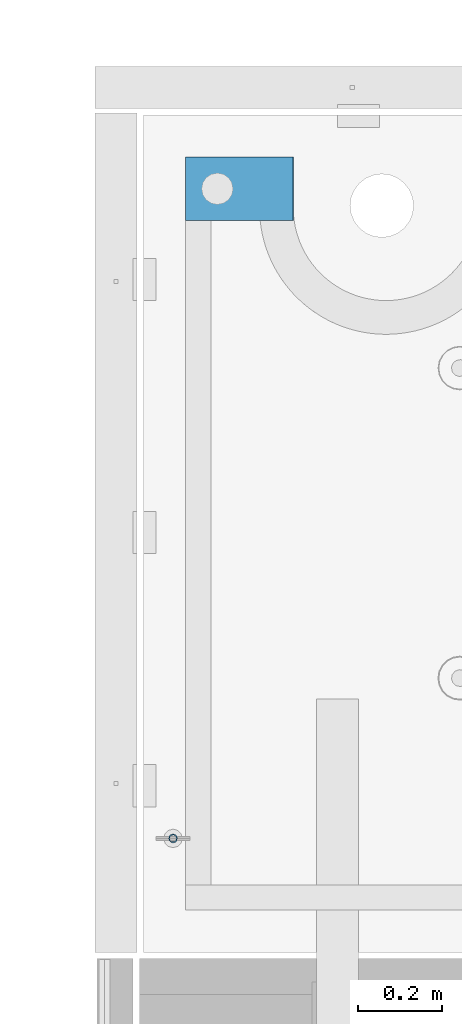
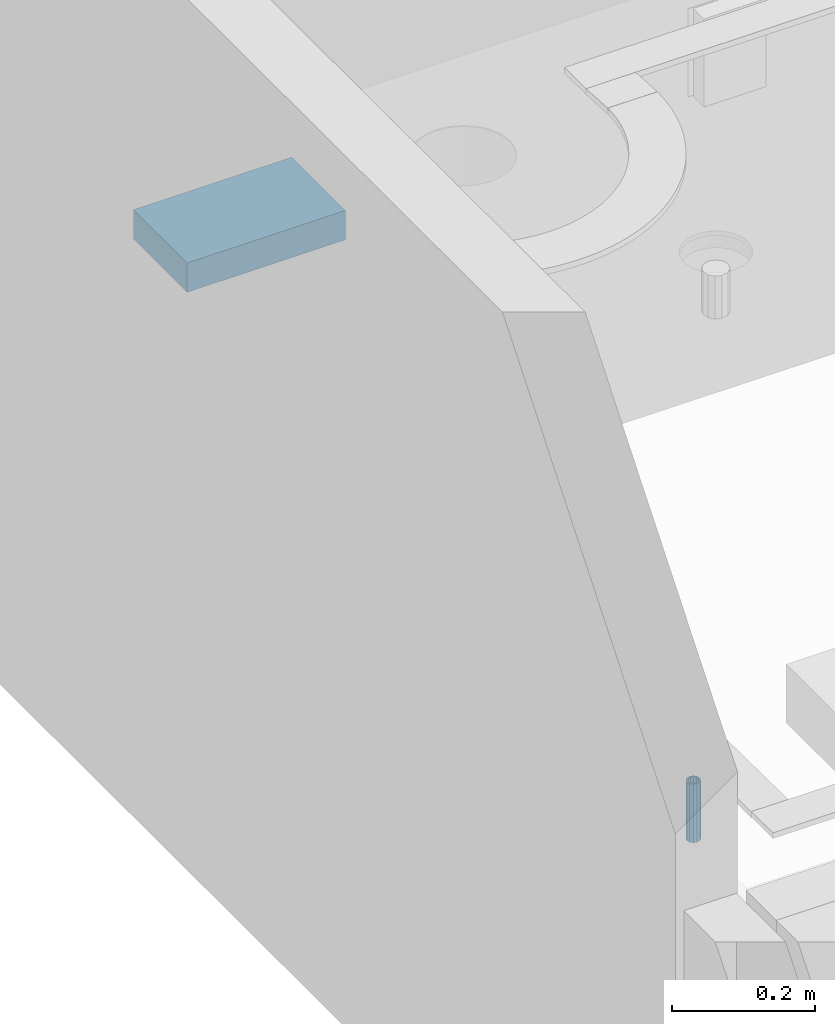
# One storey, part 134 of 325: 2 beams, 2 elements without a shape of their own.
"""IFC2X3 building model written with IfcOpenShell, lengths in millimetres."""

from ifc_helpers import new_model, si_unit, frame, origin_with_axes, place, context, subcontext, project, spatial, faceted_brep, material, type_object, element, aggregate, save


model = new_model("IFC2X3")

# Units and contexts
model_context = context("Model", 3, precision=1e-05, world=origin_with_axes())
body_context = subcontext(model_context, "Body", "Model", "MODEL_VIEW")
ifc_project = project(units=[si_unit("LENGTHUNIT", "METRE", prefix="MILLI"), si_unit("AREAUNIT", "SQUARE_METRE"), si_unit("VOLUMEUNIT", "CUBIC_METRE"), si_unit("MASSUNIT", "GRAM", prefix="KILO"), si_unit("TIMEUNIT", "SECOND"), si_unit("PLANEANGLEUNIT", "RADIAN"), si_unit("SOLIDANGLEUNIT", "STERADIAN"), si_unit("THERMODYNAMICTEMPERATUREUNIT", "DEGREE_CELSIUS"), si_unit("LUMINOUSINTENSITYUNIT", "LUMEN")], contexts=[model_context])

# Site, building, storey
site_placement = place(None, origin_with_axes())
site = spatial("IfcSite", under=ifc_project, at=site_placement, CompositionType="ELEMENT")
building_placement = place(site_placement, origin_with_axes())
building = spatial("IfcBuilding", under=site, at=building_placement, CompositionType="ELEMENT")
storey_placement = place(building_placement, origin_with_axes())
storey = spatial("IfcBuildingStorey", under=building, at=storey_placement, Name="1", CompositionType="ELEMENT", Elevation=0.0)

# Assemblies, beams
assembly_1_placement = place(storey_placement, origin_with_axes())
assembly_1 = element("IfcElementAssembly", 1, at=assembly_1_placement, inside=storey, AssemblyPlace="NOTDEFINED", PredefinedType="REINFORCEMENT_UNIT")
ifc_material_1 = material(Name="CONCRETE/Concrete_Undefined")
beam_type_1 = type_object("IfcBeamType", PredefinedType="NOTDEFINED")
beam_1_placement = place(assembly_1_placement, frame((7834.97852488622, 22709.9981419457, 84683.8130006467), z_axis=(-0.000811736999627788, 6.99999872856177e-09, 0.999999670541467), x_axis=(0.99999967050638, -8.37699998998561e-06, 0.000811736999618736)))
beam_1 = element("IfcBeam", 2, at=beam_1_placement, type_object=beam_type_1, material=ifc_material_1, context=body_context, shape_type="Brep", body=[
    faceted_brep([(0.0, 75.0, -25.0), (1.81898940354586e-12, 75.0, 25.0), (254.995831308013, 74.9999999999964, 24.9999999999709), (254.995831308012, 74.9999999999964, -25.0000000000146), (1.81898940354586e-12, -75.0000000000009, 25.0), (254.995831308014, -75.0000000000036, 24.9999999999854), (0.0, -75.0, -25.0), (254.995831308011, -75.0000000000036, -25.0000000000146)], [[[0, 1, 2, 3]], [[1, 4, 5, 2]], [[4, 6, 7, 5]], [[6, 0, 3, 7]], [[5, 7, 3, 2]], [[6, 4, 1, 0]]]),
])
assembly_2_placement = place(assembly_1_placement, origin_with_axes())
assembly_2 = element("IfcElementAssembly", 3, at=assembly_2_placement, Name="Steel Assembly", AssemblyPlace="NOTDEFINED", PredefinedType="RIGID_FRAME")
aggregate(assembly_1, [assembly_2, beam_1])
ifc_material_2 = material(Name="STEEL/1.4301")
beam_type_2 = type_object("IfcBeamType", PredefinedType="NOTDEFINED")
beam_2_placement = place(assembly_2_placement, frame((7804.99906038484, 21170.0168887697, 84726.9999983246), z_axis=(-1.43919999976435e-05, -0.999999999896435, 0.0), x_axis=(0.0, 0.0, -1.0)))
beam_2 = element("IfcBeam", 4, at=beam_2_placement, type_object=beam_type_2, material=ifc_material_2, context=body_context, shape_type="Brep", body=[
    faceted_brep([(0.0, -8.0, 0.0), (0.0, -6.92820323027263, 4.0), (100.000000000029, -6.92820323027263, 4.0), (100.000000000029, -7.99999999999636, 0.0), (0.0, -4.0, 6.92820323027627), (100.000000000029, -4.0, 6.92820323027536), (0.0, 0.0, 8.0), (100.000000000029, 3.63797880709171e-12, 8.0), (0.0, 4.0, 6.92820323027627), (100.000000000029, 4.0, 6.92820323027536), (0.0, 6.92820323027263, 4.0), (100.000000000029, 6.92820323027627, 3.99999999999909), (0.0, 8.0, 0.0), (100.000000000029, 8.0, 0.0), (0.0, 6.92820323027263, -4.0), (100.000000000029, 6.92820323027627, -4.00000000000091), (0.0, 4.0, -6.92820323027627), (100.000000000029, 4.00000000000364, -6.92820323027536), (0.0, 0.0, -8.0), (100.000000000029, 3.63797880709171e-12, -8.00000000000091), (0.0, -4.0, -6.92820323027627), (100.000000000029, -3.99999999999636, -6.92820323027627), (0.0, -6.92820323027263, -4.0), (100.000000000029, -6.92820323027263, -4.0), (0.0, -10.4999999999927, -1.45519152283669e-11), (0.0, -9.09326673972828, -5.25000000001455), (100.000000000262, -9.09326673972828, -5.25000000001455), (100.000000000262, -10.4999999999927, -1.45519152283669e-11), (0.0, -5.24999999998545, -9.09326673974283), (100.000000000262, -5.24999999998545, -9.09326673974283), (0.0, 7.27595761418343e-12, -10.5), (100.000000000262, 7.27595761418343e-12, -10.5), (0.0, 5.25000000001455, -9.09326673975738), (100.000000000262, 5.25000000001455, -9.09326673975738), (0.0, 9.09326673975011, -5.25000000001455), (100.000000000262, 9.09326673975011, -5.25000000001455), (0.0, 10.5000000000073, -1.45519152283669e-11), (100.000000000262, 10.5000000000073, -1.45519152283669e-11), (0.0, 9.09326673975011, 5.25), (100.000000000262, 9.09326673975011, 5.25), (0.0, 5.25000000000728, 9.09326673972828), (100.000000000262, 5.25000000000728, 9.09326673972828), (0.0, 1.45519152283669e-11, 10.4999999999854), (100.000000000262, 1.45519152283669e-11, 10.4999999999854), (0.0, -5.24999999999272, 9.09326673972828), (100.000000000262, -5.24999999999272, 9.09326673972828), (0.0, -9.09326673972828, 5.24999999998545), (100.000000000262, -9.09326673972828, 5.24999999998545)], [[[0, 1, 2, 3]], [[1, 4, 5, 2]], [[4, 6, 7, 5]], [[6, 8, 9, 7]], [[8, 10, 11, 9]], [[10, 12, 13, 11]], [[12, 14, 15, 13]], [[14, 16, 17, 15]], [[16, 18, 19, 17]], [[18, 20, 21, 19]], [[20, 22, 23, 21]], [[22, 0, 3, 23]], [[24, 25, 26, 27]], [[25, 28, 29, 26]], [[28, 30, 31, 29]], [[30, 32, 33, 31]], [[32, 34, 35, 33]], [[34, 36, 37, 35]], [[36, 38, 39, 37]], [[38, 40, 41, 39]], [[40, 42, 43, 41]], [[42, 44, 45, 43]], [[44, 46, 47, 45]], [[46, 24, 27, 47]], [[29, 31, 33, 35, 37, 39, 41, 43, 45, 47, 27, 26], [5, 7, 9, 11, 13, 15, 17, 19, 21, 23, 3, 2]], [[46, 44, 42, 40, 38, 36, 34, 32, 30, 28, 25, 24], [22, 20, 18, 16, 14, 12, 10, 8, 6, 4, 1, 0]]]),
])
aggregate(assembly_2, [beam_2])

save(model, "model.ifc")
